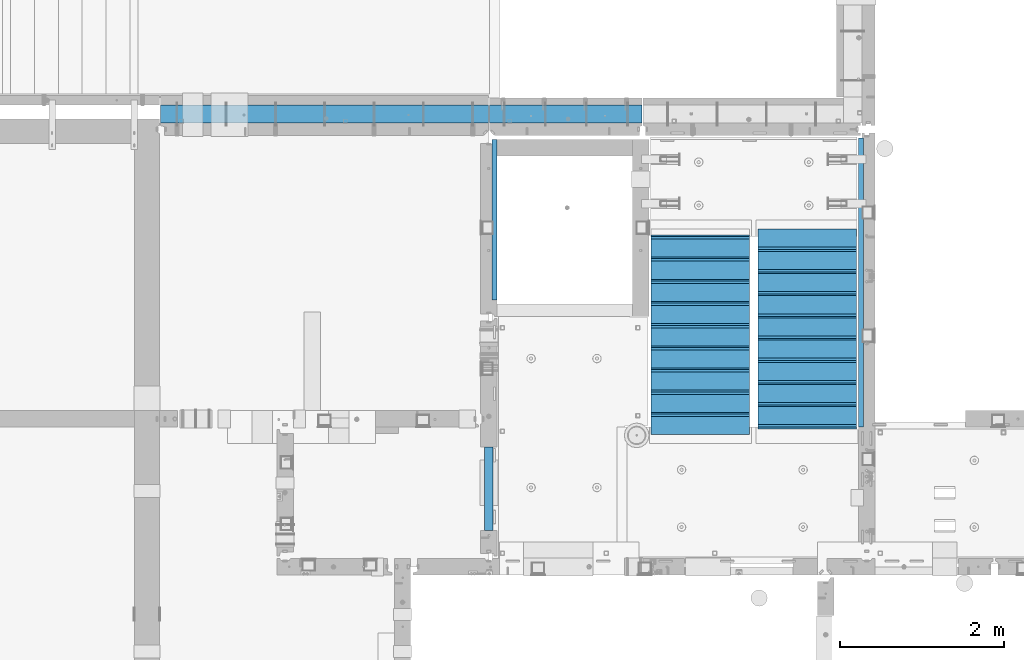
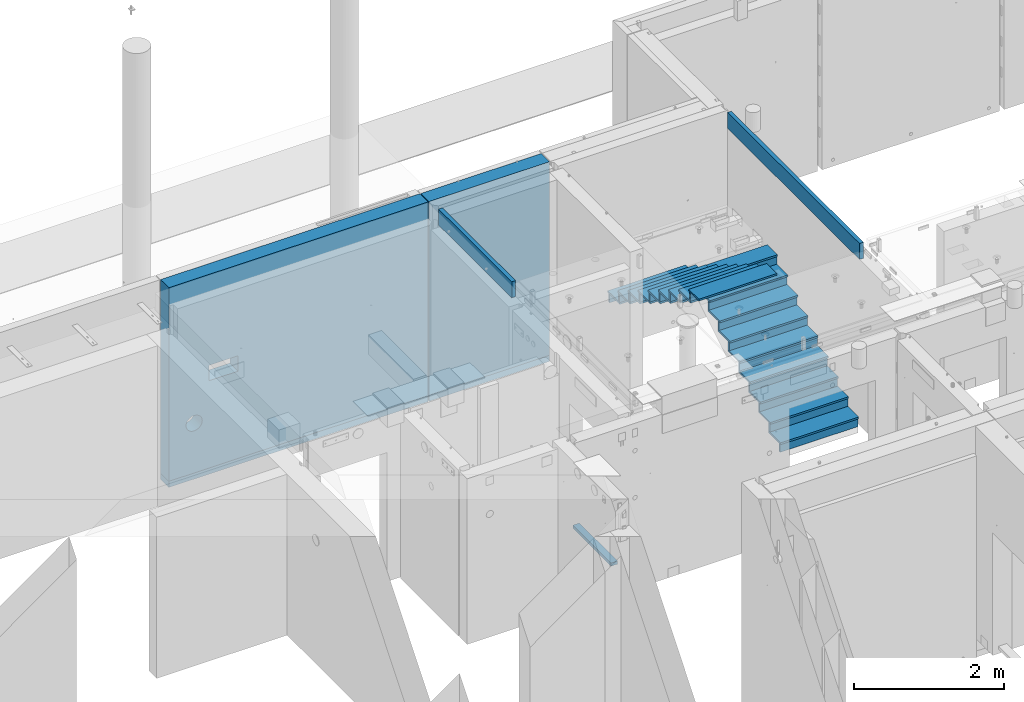
# One storey, part 81 of 264: 43 beams, 9 elements without a shape of their own.
"""IFC2X3 building model written with IfcOpenShell, lengths in millimetres."""

from ifc_helpers import new_model, si_unit, frame, origin_with_axes, place, context, subcontext, project, spatial, faceted_brep, material, type_object, element, aggregate, save


model = new_model("IFC2X3")

# Units and contexts
model_context = context("Model", 3, precision=1e-05, world=origin_with_axes())
body_context = subcontext(model_context, "Body", "Model", "MODEL_VIEW")
ifc_project = project(units=[si_unit("LENGTHUNIT", "METRE", prefix="MILLI"), si_unit("AREAUNIT", "SQUARE_METRE"), si_unit("VOLUMEUNIT", "CUBIC_METRE"), si_unit("MASSUNIT", "GRAM", prefix="KILO"), si_unit("TIMEUNIT", "SECOND"), si_unit("PLANEANGLEUNIT", "RADIAN"), si_unit("SOLIDANGLEUNIT", "STERADIAN"), si_unit("THERMODYNAMICTEMPERATUREUNIT", "DEGREE_CELSIUS"), si_unit("LUMINOUSINTENSITYUNIT", "LUMEN")], contexts=[model_context])

# Site, building, storey
site_placement = place(None, origin_with_axes())
site = spatial("IfcSite", under=ifc_project, at=site_placement, CompositionType="ELEMENT")
building_placement = place(site_placement, origin_with_axes())
building = spatial("IfcBuilding", under=site, at=building_placement, CompositionType="ELEMENT")
storey_placement = place(building_placement, origin_with_axes())
storey = spatial("IfcBuildingStorey", under=building, at=storey_placement, Name="K", CompositionType="ELEMENT", Elevation=0.0)

# Assembly, beam
assembly_1_placement = place(storey_placement, origin_with_axes())
assembly_1 = element("IfcElementAssembly", 1, at=assembly_1_placement, inside=storey, AssemblyPlace="NOTDEFINED", PredefinedType="REINFORCEMENT_UNIT")
ifc_material_1 = material(Name="CONCRETE/C25/30")
beam_type_1 = type_object("IfcBeamType", Name="260X60", PredefinedType="NOTDEFINED")
beam_1_placement = place(assembly_1_placement, frame((17779.9999105288, 18424.9992663657, 81600.0), z_axis=(0.0, 0.0, 1.0), x_axis=(0.0, 1.0, 0.0)))
beam_1 = element("IfcBeam", 2, at=beam_1_placement, type_object=beam_type_1, material=ifc_material_1, ObjectType="260X60", context=body_context, shape_type="Brep", body=[
    faceted_brep([(0.0, 30.0, -130.0), (0.0, 30.0, 130.0), (1954.9989445891, 30.0, 130.0), (1954.9989445891, 30.0, -130.0), (0.0, -30.0, 130.0), (1954.9989445891, -30.0, 130.0), (0.0, -30.0, -130.0), (1954.9989445891, -30.0, -130.0)], [[[0, 1, 2, 3]], [[1, 4, 5, 2]], [[4, 6, 7, 5]], [[6, 0, 3, 7]], [[5, 7, 3, 2]], [[6, 4, 1, 0]]]),
])
aggregate(assembly_1, [beam_1])

assembly_2_placement = place(storey_placement, origin_with_axes())
assembly_2 = element("IfcElementAssembly", 3, at=assembly_2_placement, inside=storey, AssemblyPlace="NOTDEFINED", PredefinedType="REINFORCEMENT_UNIT")
beam_2_placement = place(assembly_2_placement, frame((22240.0000000001, 20400.0, 81600.0), z_axis=(0.0, 0.0, 1.0), x_axis=(0.0, -1.0, 0.0)))
beam_2 = element("IfcBeam", 4, at=beam_2_placement, type_object=beam_type_1, material=ifc_material_1, ObjectType="260X60", context=body_context, shape_type="Brep", body=[
    faceted_brep([(0.0, 30.0, -130.0), (0.0, 30.0, 130.0), (3520.0, 30.0, 130.0), (3520.0, 30.0, -130.0), (0.0, -30.0, 130.0), (3520.0, -30.0, 130.0), (0.0, -30.0, -130.0), (3520.0, -30.0, -130.0)], [[[0, 1, 2, 3]], [[1, 4, 5, 2]], [[4, 6, 7, 5]], [[6, 0, 3, 7]], [[5, 7, 3, 2]], [[6, 4, 1, 0]]]),
])
aggregate(assembly_2, [beam_2])

assembly_3_placement = place(storey_placement, origin_with_axes())
assembly_3 = element("IfcElementAssembly", 5, at=assembly_3_placement, inside=storey, AssemblyPlace="NOTDEFINED", PredefinedType="REINFORCEMENT_UNIT")
ifc_material_2 = material(Name="TIMBER/T24")
beam_type_2 = type_object("IfcBeamType", PredefinedType="NOTDEFINED")
beam_3_placement = place(assembly_3_placement, frame((17710.0, 15620.0003036857, 78860.0), z_axis=(0.0, 0.0, 1.0), x_axis=(0.0, 1.0, 0.0)))
beam_3 = element("IfcBeam", 6, at=beam_3_placement, type_object=beam_type_2, material=ifc_material_2, context=body_context, shape_type="Brep", body=[
    faceted_brep([(0.0, 50.0, -25.0), (0.0, 50.0, 25.0), (1020.0, 50.0, 25.0), (1020.0, 50.0, -25.0), (0.0, -50.0, 25.0), (1020.0, -50.0, 25.0), (0.0, -50.0, -25.0), (1020.0, -50.0, -25.0)], [[[0, 1, 2, 3]], [[1, 4, 5, 2]], [[4, 6, 7, 5]], [[6, 0, 3, 7]], [[5, 7, 3, 2]], [[6, 4, 1, 0]]]),
])
aggregate(assembly_3, [beam_3])

assembly_4_placement = place(storey_placement, origin_with_axes())
assembly_4 = element("IfcElementAssembly", 7, at=assembly_4_placement, inside=storey, AssemblyPlace="NOTDEFINED", PredefinedType="REINFORCEMENT_UNIT")
beam_type_3 = type_object("IfcBeamType", PredefinedType="NOTDEFINED")
beam_4_placement = place(assembly_4_placement, frame((19575.0014026565, 20689.9988548915, 78540.0), z_axis=(0.0, 0.0, 1.0), x_axis=(-1.0, 3.00000001838171e-08, 0.0)))
beam_4 = element("IfcBeam", 8, at=beam_4_placement, type_object=beam_type_3, material=ifc_material_1, context=body_context, shape_type="Brep", body=[
    faceted_brep([(-3.63797880709171e-12, 109.999999999996, -50.0), (-3.63797880709171e-12, 109.999999999996, 50.0), (1855.00147016809, 109.999999999996, 50.0), (1855.00147016809, 109.999999999996, -50.0), (-3.63797880709171e-12, -110.0, 50.0), (1855.00147016809, -110.0, 50.0), (-3.63797880709171e-12, -110.0, -50.0), (1855.00147016809, -110.0, -50.0)], [[[0, 1, 2, 3]], [[1, 4, 5, 2]], [[4, 6, 7, 5]], [[6, 0, 3, 7]], [[5, 7, 3, 2]], [[6, 4, 1, 0]]]),
])

assembly_5_placement = place(storey_placement, origin_with_axes())
assembly_5 = element("IfcElementAssembly", 9, at=assembly_5_placement, inside=storey, AssemblyPlace="NOTDEFINED", PredefinedType="REINFORCEMENT_UNIT")
beam_5_placement = place(assembly_5_placement, frame((13715.0034045212, 20689.9999956824, 78540.0), z_axis=(0.0, 0.0, 1.0), x_axis=(1.0, 0.0, 0.0)))
beam_5 = element("IfcBeam", 10, at=beam_5_placement, type_object=beam_type_3, material=ifc_material_1, context=body_context, shape_type="Brep", body=[
    faceted_brep([(-3.63797880709171e-12, 109.999999999996, -50.0), (-3.63797880709171e-12, 109.999999999996, 50.0), (3989.996563799, 110.000000000004, 50.0), (3989.996563799, 110.000000000004, -50.0), (-3.63797880709171e-12, -110.0, 50.0), (3989.996627159, -109.999999999996, 50.0), (-3.63797880709171e-12, -110.0, -50.0), (3989.996627159, -109.999999999996, -50.0)], [[[0, 1, 2, 3]], [[1, 4, 5, 2]], [[4, 6, 7, 5]], [[6, 0, 3, 7]], [[5, 7, 3, 2]], [[6, 4, 1, 0]]]),
])

# Assembly, beams
assembly_6_placement = place(storey_placement, origin_with_axes())
assembly_6 = element("IfcElementAssembly", 11, at=assembly_6_placement, inside=storey, Name="E9", AssemblyPlace="NOTDEFINED", PredefinedType="NOTDEFINED")
ifc_material_3 = material(Name="Undefined/C32/40")
beam_type_4 = type_object("IfcBeamType", PredefinedType="NOTDEFINED")
beam_6_placement = place(assembly_6_placement, frame((20885.0002457424, 17024.9998138874, 81662.1), z_axis=(0.0, 1.0, 0.0), x_axis=(-1.0, 3.00000001838171e-08, 0.0)))
beam_6 = element("IfcBeam", 12, at=beam_6_placement, type_object=beam_type_4, material=ifc_material_3, Name="E9", context=body_context, shape_type="Brep", body=[
    faceted_brep([(0.0, 68.5, -15.0), (0.0, 68.5, 15.0), (1200.0, 68.5, 15.0), (1200.0, 68.5, -15.0), (0.0, -68.5, 15.0), (1200.0, -68.5, 15.0), (0.0, -68.5, -15.0), (1200.0, -68.5, -15.0)], [[[0, 1, 2, 3]], [[1, 4, 5, 2]], [[4, 6, 7, 5]], [[6, 0, 3, 7]], [[5, 7, 3, 2]], [[6, 4, 1, 0]]]),
])
beam_7_placement = place(assembly_6_placement, frame((20885.0002457424, 17294.9998138874, 81495.4), z_axis=(0.0, 1.0, 0.0), x_axis=(-1.0, 3.00000001838171e-08, 0.0)))
beam_7 = element("IfcBeam", 13, at=beam_7_placement, type_object=beam_type_4, material=ifc_material_3, Name="E9", context=body_context, shape_type="Brep", body=[
    faceted_brep([(0.0, 68.5, -15.0), (0.0, 68.5, 15.0), (1200.0, 68.5, 15.0), (1200.0, 68.5, -15.0), (0.0, -68.5, 15.0), (1200.0, -68.5, 15.0), (0.0, -68.5, -15.0), (1200.0, -68.5, -15.0)], [[[0, 1, 2, 3]], [[1, 4, 5, 2]], [[4, 6, 7, 5]], [[6, 0, 3, 7]], [[5, 7, 3, 2]], [[6, 4, 1, 0]]]),
])
beam_8_placement = place(assembly_6_placement, frame((20885.0002457424, 17564.9998138874, 81328.7), z_axis=(0.0, 1.0, 0.0), x_axis=(-1.0, 3.00000001838171e-08, 0.0)))
beam_8 = element("IfcBeam", 14, at=beam_8_placement, type_object=beam_type_4, material=ifc_material_3, Name="E9", context=body_context, shape_type="Brep", body=[
    faceted_brep([(0.0, 68.5, -15.0), (0.0, 68.5, 15.0), (1200.0, 68.5, 15.0), (1200.0, 68.5, -15.0), (0.0, -68.5, 15.0), (1200.0, -68.5, 15.0), (0.0, -68.5, -15.0), (1200.0, -68.5, -15.0)], [[[0, 1, 2, 3]], [[1, 4, 5, 2]], [[4, 6, 7, 5]], [[6, 0, 3, 7]], [[5, 7, 3, 2]], [[6, 4, 1, 0]]]),
])
beam_9_placement = place(assembly_6_placement, frame((20885.0002457424, 17834.9998138874, 81162.0), z_axis=(0.0, 1.0, 0.0), x_axis=(-1.0, 3.00000001838171e-08, 0.0)))
beam_9 = element("IfcBeam", 15, at=beam_9_placement, type_object=beam_type_4, material=ifc_material_3, Name="E9", context=body_context, shape_type="Brep", body=[
    faceted_brep([(0.0, 68.5, -15.0), (0.0, 68.5, 15.0), (1200.0, 68.5, 15.0), (1200.0, 68.5, -15.0), (0.0, -68.5, 15.0), (1200.0, -68.5, 15.0), (0.0, -68.5, -15.0), (1200.0, -68.5, -15.0)], [[[0, 1, 2, 3]], [[1, 4, 5, 2]], [[4, 6, 7, 5]], [[6, 0, 3, 7]], [[5, 7, 3, 2]], [[6, 4, 1, 0]]]),
])
beam_10_placement = place(assembly_6_placement, frame((20885.0002457424, 18104.9998138874, 80995.3), z_axis=(0.0, 1.0, 0.0), x_axis=(-1.0, 3.00000001838171e-08, 0.0)))
beam_10 = element("IfcBeam", 16, at=beam_10_placement, type_object=beam_type_4, material=ifc_material_3, Name="E9", context=body_context, shape_type="Brep", body=[
    faceted_brep([(0.0, 68.5, -15.0), (0.0, 68.5, 15.0), (1200.0, 68.5, 15.0), (1200.0, 68.5, -15.0), (0.0, -68.5, 15.0), (1200.0, -68.5, 15.0), (0.0, -68.5, -15.0), (1200.0, -68.5, -15.0)], [[[0, 1, 2, 3]], [[1, 4, 5, 2]], [[4, 6, 7, 5]], [[6, 0, 3, 7]], [[5, 7, 3, 2]], [[6, 4, 1, 0]]]),
])
beam_11_placement = place(assembly_6_placement, frame((20885.0002457424, 18374.9998138874, 80828.6), z_axis=(0.0, 1.0, 0.0), x_axis=(-1.0, 3.00000001838171e-08, 0.0)))
beam_11 = element("IfcBeam", 17, at=beam_11_placement, type_object=beam_type_4, material=ifc_material_3, Name="E9", context=body_context, shape_type="Brep", body=[
    faceted_brep([(0.0, 68.5, -15.0), (0.0, 68.5, 15.0), (1200.0, 68.5, 15.0), (1200.0, 68.5, -15.0), (0.0, -68.5, 15.0), (1200.0, -68.5, 15.0), (0.0, -68.5, -15.0), (1200.0, -68.5, -15.0)], [[[0, 1, 2, 3]], [[1, 4, 5, 2]], [[4, 6, 7, 5]], [[6, 0, 3, 7]], [[5, 7, 3, 2]], [[6, 4, 1, 0]]]),
])
beam_12_placement = place(assembly_6_placement, frame((20885.0002457424, 18644.9998138874, 80661.9), z_axis=(0.0, 1.0, 0.0), x_axis=(-1.0, 3.00000001838171e-08, 0.0)))
beam_12 = element("IfcBeam", 18, at=beam_12_placement, type_object=beam_type_4, material=ifc_material_3, Name="E9", context=body_context, shape_type="Brep", body=[
    faceted_brep([(0.0, 68.5, -15.0), (0.0, 68.5, 15.0), (1200.0, 68.5, 15.0), (1200.0, 68.5, -15.0), (0.0, -68.5, 15.0), (1200.0, -68.5, 15.0), (0.0, -68.5, -15.0), (1200.0, -68.5, -15.0)], [[[0, 1, 2, 3]], [[1, 4, 5, 2]], [[4, 6, 7, 5]], [[6, 0, 3, 7]], [[5, 7, 3, 2]], [[6, 4, 1, 0]]]),
])
beam_13_placement = place(assembly_6_placement, frame((20885.0002457424, 18914.9998138874, 80495.2), z_axis=(0.0, 1.0, 0.0), x_axis=(-1.0, 3.00000001838171e-08, 0.0)))
beam_13 = element("IfcBeam", 19, at=beam_13_placement, type_object=beam_type_4, material=ifc_material_3, Name="E9", context=body_context, shape_type="Brep", body=[
    faceted_brep([(0.0, 68.5, -15.0), (0.0, 68.5, 15.0), (1200.0, 68.5, 15.0), (1200.0, 68.5, -15.0), (0.0, -68.5, 15.0), (1200.0, -68.5, 15.0), (0.0, -68.5, -15.0), (1200.0, -68.5, -15.0)], [[[0, 1, 2, 3]], [[1, 4, 5, 2]], [[4, 6, 7, 5]], [[6, 0, 3, 7]], [[5, 7, 3, 2]], [[6, 4, 1, 0]]]),
])
beam_14_placement = place(assembly_6_placement, frame((20885.0002457424, 19184.9998138874, 80328.5), z_axis=(0.0, 1.0, 0.0), x_axis=(-1.0, 3.00000001838171e-08, 0.0)))
beam_14 = element("IfcBeam", 20, at=beam_14_placement, type_object=beam_type_4, material=ifc_material_3, Name="E9", context=body_context, shape_type="Brep", body=[
    faceted_brep([(0.0, 68.5, -15.0), (0.0, 68.5, 15.0), (1200.0, 68.5, 15.0), (1200.0, 68.5, -15.0), (0.0, -68.5, 15.0), (1200.0, -68.5, 15.0), (0.0, -68.5, -15.0), (1200.0, -68.5, -15.0)], [[[0, 1, 2, 3]], [[1, 4, 5, 2]], [[4, 6, 7, 5]], [[6, 0, 3, 7]], [[5, 7, 3, 2]], [[6, 4, 1, 0]]]),
])

assembly_7_placement = place(storey_placement, origin_with_axes())
assembly_7 = element("IfcElementAssembly", 21, at=assembly_7_placement, inside=storey, Name="E9", AssemblyPlace="NOTDEFINED", PredefinedType="NOTDEFINED")
beam_15_placement = place(assembly_7_placement, frame((20985.002175553, 18785.0053086308, 79995.098366371), z_axis=(0.0, -1.0, 0.0), x_axis=(1.0, 0.0, 0.0)))
beam_15 = element("IfcBeam", 22, at=beam_15_placement, type_object=beam_type_4, material=ifc_material_3, Name="E9", context=body_context, shape_type="Brep", body=[
    faceted_brep([(0.0, 68.5, -15.0), (0.0, 68.5, 15.0), (1200.0, 68.5, 15.0), (1200.0, 68.5, -15.0), (0.0, -68.5, 15.0), (1200.0, -68.5, 15.0), (0.0, -68.5, -15.0), (1200.0, -68.5, -15.0)], [[[0, 1, 2, 3]], [[1, 4, 5, 2]], [[4, 6, 7, 5]], [[6, 0, 3, 7]], [[5, 7, 3, 2]], [[6, 4, 1, 0]]]),
])
beam_16_placement = place(assembly_7_placement, frame((20985.002175553, 18515.0053086308, 79828.398366371), z_axis=(0.0, -1.0, 0.0), x_axis=(1.0, 0.0, 0.0)))
beam_16 = element("IfcBeam", 23, at=beam_16_placement, type_object=beam_type_4, material=ifc_material_3, Name="E9", context=body_context, shape_type="Brep", body=[
    faceted_brep([(0.0, 68.5, -15.0), (0.0, 68.5, 15.0), (1200.0, 68.5, 15.0), (1200.0, 68.5, -15.0), (0.0, -68.5, 15.0), (1200.0, -68.5, 15.0), (0.0, -68.5, -15.0), (1200.0, -68.5, -15.0)], [[[0, 1, 2, 3]], [[1, 4, 5, 2]], [[4, 6, 7, 5]], [[6, 0, 3, 7]], [[5, 7, 3, 2]], [[6, 4, 1, 0]]]),
])
beam_17_placement = place(assembly_7_placement, frame((20985.002175553, 18245.0053086308, 79661.698366371), z_axis=(0.0, -1.0, 0.0), x_axis=(1.0, 0.0, 0.0)))
beam_17 = element("IfcBeam", 24, at=beam_17_placement, type_object=beam_type_4, material=ifc_material_3, Name="E9", context=body_context, shape_type="Brep", body=[
    faceted_brep([(0.0, 68.5, -15.0), (0.0, 68.5, 15.0), (1200.0, 68.5, 15.0), (1200.0, 68.5, -15.0), (0.0, -68.5, 15.0), (1200.0, -68.5, 15.0), (0.0, -68.5, -15.0), (1200.0, -68.5, -15.0)], [[[0, 1, 2, 3]], [[1, 4, 5, 2]], [[4, 6, 7, 5]], [[6, 0, 3, 7]], [[5, 7, 3, 2]], [[6, 4, 1, 0]]]),
])
beam_18_placement = place(assembly_7_placement, frame((20985.002175553, 17975.0053086308, 79494.998366371), z_axis=(0.0, -1.0, 0.0), x_axis=(1.0, 0.0, 0.0)))
beam_18 = element("IfcBeam", 25, at=beam_18_placement, type_object=beam_type_4, material=ifc_material_3, Name="E9", context=body_context, shape_type="Brep", body=[
    faceted_brep([(0.0, 68.5, -15.0), (0.0, 68.5, 15.0), (1200.0, 68.5, 15.0), (1200.0, 68.5, -15.0), (0.0, -68.5, 15.0), (1200.0, -68.5, 15.0), (0.0, -68.5, -15.0), (1200.0, -68.5, -15.0)], [[[0, 1, 2, 3]], [[1, 4, 5, 2]], [[4, 6, 7, 5]], [[6, 0, 3, 7]], [[5, 7, 3, 2]], [[6, 4, 1, 0]]]),
])
beam_19_placement = place(assembly_7_placement, frame((20985.002175553, 17705.0053086308, 79328.298366371), z_axis=(0.0, -1.0, 0.0), x_axis=(1.0, 0.0, 0.0)))
beam_19 = element("IfcBeam", 26, at=beam_19_placement, type_object=beam_type_4, material=ifc_material_3, Name="E9", context=body_context, shape_type="Brep", body=[
    faceted_brep([(0.0, 68.5, -15.0), (0.0, 68.5, 15.0), (1200.0, 68.5, 15.0), (1200.0, 68.5, -15.0), (0.0, -68.5, 15.0), (1200.0, -68.5, 15.0), (0.0, -68.5, -15.0), (1200.0, -68.5, -15.0)], [[[0, 1, 2, 3]], [[1, 4, 5, 2]], [[4, 6, 7, 5]], [[6, 0, 3, 7]], [[5, 7, 3, 2]], [[6, 4, 1, 0]]]),
])
beam_20_placement = place(assembly_7_placement, frame((20985.002175553, 17435.0053086308, 79161.598366371), z_axis=(0.0, -1.0, 0.0), x_axis=(1.0, 0.0, 0.0)))
beam_20 = element("IfcBeam", 27, at=beam_20_placement, type_object=beam_type_4, material=ifc_material_3, Name="E9", context=body_context, shape_type="Brep", body=[
    faceted_brep([(0.0, 68.5, -15.0), (0.0, 68.5, 15.0), (1200.0, 68.5, 15.0), (1200.0, 68.5, -15.0), (0.0, -68.5, 15.0), (1200.0, -68.5, 15.0), (0.0, -68.5, -15.0), (1200.0, -68.5, -15.0)], [[[0, 1, 2, 3]], [[1, 4, 5, 2]], [[4, 6, 7, 5]], [[6, 0, 3, 7]], [[5, 7, 3, 2]], [[6, 4, 1, 0]]]),
])
beam_21_placement = place(assembly_7_placement, frame((20985.002175553, 17165.0053086308, 78994.898366371), z_axis=(0.0, -1.0, 0.0), x_axis=(1.0, 0.0, 0.0)))
beam_21 = element("IfcBeam", 28, at=beam_21_placement, type_object=beam_type_4, material=ifc_material_3, Name="E9", context=body_context, shape_type="Brep", body=[
    faceted_brep([(0.0, 68.5, -15.0), (0.0, 68.5, 15.0), (1200.0, 68.5, 15.0), (1200.0, 68.5, -15.0), (0.0, -68.5, 15.0), (1200.0, -68.5, 15.0), (0.0, -68.5, -15.0), (1200.0, -68.5, -15.0)], [[[0, 1, 2, 3]], [[1, 4, 5, 2]], [[4, 6, 7, 5]], [[6, 0, 3, 7]], [[5, 7, 3, 2]], [[6, 4, 1, 0]]]),
])
beam_22_placement = place(assembly_7_placement, frame((20985.002175553, 19055.0053086308, 80161.798366371), z_axis=(0.0, -1.0, 0.0), x_axis=(1.0, 0.0, 0.0)))
beam_22 = element("IfcBeam", 29, at=beam_22_placement, type_object=beam_type_4, material=ifc_material_3, Name="E9", context=body_context, shape_type="Brep", body=[
    faceted_brep([(0.0, 68.5, -15.0), (0.0, 68.5, 15.0), (1200.0, 68.5, 15.0), (1200.0, 68.5, -15.0), (0.0, -68.5, 15.0), (1200.0, -68.5, 15.0), (0.0, -68.5, -15.0), (1200.0, -68.5, -15.0)], [[[0, 1, 2, 3]], [[1, 4, 5, 2]], [[4, 6, 7, 5]], [[6, 0, 3, 7]], [[5, 7, 3, 2]], [[6, 4, 1, 0]]]),
])
beam_23_placement = place(assembly_7_placement, frame((20985.002175553, 16895.0053086308, 78828.198366371), z_axis=(0.0, -1.0, 0.0), x_axis=(1.0, 0.0, 0.0)))
beam_23 = element("IfcBeam", 30, at=beam_23_placement, type_object=beam_type_4, material=ifc_material_3, Name="E9", context=body_context, shape_type="Brep", body=[
    faceted_brep([(0.0, 68.5, -15.0), (0.0, 68.5, 15.0), (1200.0, 68.5, 15.0), (1200.0, 68.5, -15.0), (0.0, -68.5, 15.0), (1200.0, -68.5, 15.0), (0.0, -68.5, -15.0), (1200.0, -68.5, -15.0)], [[[0, 1, 2, 3]], [[1, 4, 5, 2]], [[4, 6, 7, 5]], [[6, 0, 3, 7]], [[5, 7, 3, 2]], [[6, 4, 1, 0]]]),
])

# Beam
beam_type_5 = type_object("IfcBeamType", PredefinedType="NOTDEFINED")
beam_24_placement = place(assembly_6_placement, frame((20885.0002457424, 17169.9998138874, 81578.6), z_axis=(0.0, 1.0, 0.0), x_axis=(-1.0, 3.00000001838171e-08, 0.0)))
beam_24 = element("IfcBeam", 31, at=beam_24_placement, type_object=beam_type_5, material=ifc_material_3, Name="E9", context=body_context, shape_type="Brep", body=[
    faceted_brep([(0.0, 15.0, -160.0), (0.0, 15.0, 160.0), (1200.0, 15.0, 160.0), (1200.0, 15.0, -160.0), (0.0, -15.0, 160.0), (1200.0, -15.0, 160.0), (0.0, -15.0, -160.0), (1200.0, -15.0, -160.0)], [[[0, 1, 2, 3]], [[1, 4, 5, 2]], [[4, 6, 7, 5]], [[6, 0, 3, 7]], [[5, 7, 3, 2]], [[6, 4, 1, 0]]]),
])

beam_25_placement = place(assembly_6_placement, frame((20885.0002457424, 17439.9998138874, 81411.9), z_axis=(0.0, 1.0, 0.0), x_axis=(-1.0, 3.00000001838171e-08, 0.0)))
beam_25 = element("IfcBeam", 32, at=beam_25_placement, type_object=beam_type_5, material=ifc_material_3, Name="E9", context=body_context, shape_type="Brep", body=[
    faceted_brep([(0.0, 15.0, -160.0), (0.0, 15.0, 160.0), (1200.0, 15.0, 160.0), (1200.0, 15.0, -160.0), (0.0, -15.0, 160.0), (1200.0, -15.0, 160.0), (0.0, -15.0, -160.0), (1200.0, -15.0, -160.0)], [[[0, 1, 2, 3]], [[1, 4, 5, 2]], [[4, 6, 7, 5]], [[6, 0, 3, 7]], [[5, 7, 3, 2]], [[6, 4, 1, 0]]]),
])

beam_26_placement = place(assembly_6_placement, frame((20885.0002457424, 17709.9998138874, 81245.2), z_axis=(0.0, 1.0, 0.0), x_axis=(-1.0, 3.00000001838171e-08, 0.0)))
beam_26 = element("IfcBeam", 33, at=beam_26_placement, type_object=beam_type_5, material=ifc_material_3, Name="E9", context=body_context, shape_type="Brep", body=[
    faceted_brep([(0.0, 15.0, -160.0), (0.0, 15.0, 160.0), (1200.0, 15.0, 160.0), (1200.0, 15.0, -160.0), (0.0, -15.0, 160.0), (1200.0, -15.0, 160.0), (0.0, -15.0, -160.0), (1200.0, -15.0, -160.0)], [[[0, 1, 2, 3]], [[1, 4, 5, 2]], [[4, 6, 7, 5]], [[6, 0, 3, 7]], [[5, 7, 3, 2]], [[6, 4, 1, 0]]]),
])

beam_27_placement = place(assembly_6_placement, frame((20885.0002457424, 17979.9998138874, 81078.5), z_axis=(0.0, 1.0, 0.0), x_axis=(-1.0, 3.00000001838171e-08, 0.0)))
beam_27 = element("IfcBeam", 34, at=beam_27_placement, type_object=beam_type_5, material=ifc_material_3, Name="E9", context=body_context, shape_type="Brep", body=[
    faceted_brep([(0.0, 15.0, -160.0), (0.0, 15.0, 160.0), (1200.0, 15.0, 160.0), (1200.0, 15.0, -160.0), (0.0, -15.0, 160.0), (1200.0, -15.0, 160.0), (0.0, -15.0, -160.0), (1200.0, -15.0, -160.0)], [[[0, 1, 2, 3]], [[1, 4, 5, 2]], [[4, 6, 7, 5]], [[6, 0, 3, 7]], [[5, 7, 3, 2]], [[6, 4, 1, 0]]]),
])

beam_28_placement = place(assembly_6_placement, frame((20885.0002457424, 18249.9998138874, 80911.8), z_axis=(0.0, 1.0, 0.0), x_axis=(-1.0, 3.00000001838171e-08, 0.0)))
beam_28 = element("IfcBeam", 35, at=beam_28_placement, type_object=beam_type_5, material=ifc_material_3, Name="E9", context=body_context, shape_type="Brep", body=[
    faceted_brep([(0.0, 15.0, -160.0), (0.0, 15.0, 160.0), (1200.0, 15.0, 160.0), (1200.0, 15.0, -160.0), (0.0, -15.0, 160.0), (1200.0, -15.0, 160.0), (0.0, -15.0, -160.0), (1200.0, -15.0, -160.0)], [[[0, 1, 2, 3]], [[1, 4, 5, 2]], [[4, 6, 7, 5]], [[6, 0, 3, 7]], [[5, 7, 3, 2]], [[6, 4, 1, 0]]]),
])

beam_29_placement = place(assembly_6_placement, frame((20885.0002457424, 18519.9998138874, 80745.1), z_axis=(0.0, 1.0, 0.0), x_axis=(-1.0, 3.00000001838171e-08, 0.0)))
beam_29 = element("IfcBeam", 36, at=beam_29_placement, type_object=beam_type_5, material=ifc_material_3, Name="E9", context=body_context, shape_type="Brep", body=[
    faceted_brep([(0.0, 15.0, -160.0), (0.0, 15.0, 160.0), (1200.0, 15.0, 160.0), (1200.0, 15.0, -160.0), (0.0, -15.0, 160.0), (1200.0, -15.0, 160.0), (0.0, -15.0, -160.0), (1200.0, -15.0, -160.0)], [[[0, 1, 2, 3]], [[1, 4, 5, 2]], [[4, 6, 7, 5]], [[6, 0, 3, 7]], [[5, 7, 3, 2]], [[6, 4, 1, 0]]]),
])

beam_30_placement = place(assembly_6_placement, frame((20885.0002457424, 18789.9998138874, 80578.4), z_axis=(0.0, 1.0, 0.0), x_axis=(-1.0, 3.00000001838171e-08, 0.0)))
beam_30 = element("IfcBeam", 37, at=beam_30_placement, type_object=beam_type_5, material=ifc_material_3, Name="E9", context=body_context, shape_type="Brep", body=[
    faceted_brep([(0.0, 15.0, -160.0), (0.0, 15.0, 160.0), (1200.0, 15.0, 160.0), (1200.0, 15.0, -160.0), (0.0, -15.0, 160.0), (1200.0, -15.0, 160.0), (0.0, -15.0, -160.0), (1200.0, -15.0, -160.0)], [[[0, 1, 2, 3]], [[1, 4, 5, 2]], [[4, 6, 7, 5]], [[6, 0, 3, 7]], [[5, 7, 3, 2]], [[6, 4, 1, 0]]]),
])

beam_31_placement = place(assembly_6_placement, frame((20885.0002457424, 19059.9998138874, 80411.7), z_axis=(0.0, 1.0, 0.0), x_axis=(-1.0, 3.00000001838171e-08, 0.0)))
beam_31 = element("IfcBeam", 38, at=beam_31_placement, type_object=beam_type_5, material=ifc_material_3, Name="E9", context=body_context, shape_type="Brep", body=[
    faceted_brep([(0.0, 15.0, -160.0), (0.0, 15.0, 160.0), (1200.0, 15.0, 160.0), (1200.0, 15.0, -160.0), (0.0, -15.0, 160.0), (1200.0, -15.0, 160.0), (0.0, -15.0, -160.0), (1200.0, -15.0, -160.0)], [[[0, 1, 2, 3]], [[1, 4, 5, 2]], [[4, 6, 7, 5]], [[6, 0, 3, 7]], [[5, 7, 3, 2]], [[6, 4, 1, 0]]]),
])

beam_32_placement = place(assembly_7_placement, frame((20985.002175553, 18910.0053086308, 80078.298366371), z_axis=(0.0, -1.0, 0.0), x_axis=(1.0, 0.0, 0.0)))
beam_32 = element("IfcBeam", 39, at=beam_32_placement, type_object=beam_type_5, material=ifc_material_3, Name="E9", context=body_context, shape_type="Brep", body=[
    faceted_brep([(0.0, 15.0, -160.0), (0.0, 15.0, 160.0), (1200.0, 15.0, 160.0), (1200.0, 15.0, -160.0), (0.0, -15.0, 160.0), (1200.0, -15.0, 160.0), (0.0, -15.0, -160.0), (1200.0, -15.0, -160.0)], [[[0, 1, 2, 3]], [[1, 4, 5, 2]], [[4, 6, 7, 5]], [[6, 0, 3, 7]], [[5, 7, 3, 2]], [[6, 4, 1, 0]]]),
])

beam_33_placement = place(assembly_7_placement, frame((20985.002175553, 18640.0053086308, 79911.598366371), z_axis=(0.0, -1.0, 0.0), x_axis=(1.0, 0.0, 0.0)))
beam_33 = element("IfcBeam", 40, at=beam_33_placement, type_object=beam_type_5, material=ifc_material_3, Name="E9", context=body_context, shape_type="Brep", body=[
    faceted_brep([(0.0, 15.0, -160.0), (0.0, 15.0, 160.0), (1200.0, 15.0, 160.0), (1200.0, 15.0, -160.0), (0.0, -15.0, 160.0), (1200.0, -15.0, 160.0), (0.0, -15.0, -160.0), (1200.0, -15.0, -160.0)], [[[0, 1, 2, 3]], [[1, 4, 5, 2]], [[4, 6, 7, 5]], [[6, 0, 3, 7]], [[5, 7, 3, 2]], [[6, 4, 1, 0]]]),
])

beam_34_placement = place(assembly_7_placement, frame((20985.002175553, 18100.0053086308, 79578.198366371), z_axis=(0.0, -1.0, 0.0), x_axis=(1.0, 0.0, 0.0)))
beam_34 = element("IfcBeam", 41, at=beam_34_placement, type_object=beam_type_5, material=ifc_material_3, Name="E9", context=body_context, shape_type="Brep", body=[
    faceted_brep([(0.0, 15.0, -160.0), (0.0, 15.0, 160.0), (1200.0, 15.0, 160.0), (1200.0, 15.0, -160.0), (0.0, -15.0, 160.0), (1200.0, -15.0, 160.0), (0.0, -15.0, -160.0), (1200.0, -15.0, -160.0)], [[[0, 1, 2, 3]], [[1, 4, 5, 2]], [[4, 6, 7, 5]], [[6, 0, 3, 7]], [[5, 7, 3, 2]], [[6, 4, 1, 0]]]),
])

beam_35_placement = place(assembly_7_placement, frame((20985.002175553, 17830.0053086308, 79411.498366371), z_axis=(0.0, -1.0, 0.0), x_axis=(1.0, 0.0, 0.0)))
beam_35 = element("IfcBeam", 42, at=beam_35_placement, type_object=beam_type_5, material=ifc_material_3, Name="E9", context=body_context, shape_type="Brep", body=[
    faceted_brep([(0.0, 15.0, -160.0), (0.0, 15.0, 160.0), (1200.0, 15.0, 160.0), (1200.0, 15.0, -160.0), (0.0, -15.0, 160.0), (1200.0, -15.0, 160.0), (0.0, -15.0, -160.0), (1200.0, -15.0, -160.0)], [[[0, 1, 2, 3]], [[1, 4, 5, 2]], [[4, 6, 7, 5]], [[6, 0, 3, 7]], [[5, 7, 3, 2]], [[6, 4, 1, 0]]]),
])

beam_36_placement = place(assembly_7_placement, frame((20985.002175553, 17560.0053086308, 79244.798366371), z_axis=(0.0, -1.0, 0.0), x_axis=(1.0, 0.0, 0.0)))
beam_36 = element("IfcBeam", 43, at=beam_36_placement, type_object=beam_type_5, material=ifc_material_3, Name="E9", context=body_context, shape_type="Brep", body=[
    faceted_brep([(0.0, 15.0, -160.0), (0.0, 15.0, 160.0), (1200.0, 15.0, 160.0), (1200.0, 15.0, -160.0), (0.0, -15.0, 160.0), (1200.0, -15.0, 160.0), (0.0, -15.0, -160.0), (1200.0, -15.0, -160.0)], [[[0, 1, 2, 3]], [[1, 4, 5, 2]], [[4, 6, 7, 5]], [[6, 0, 3, 7]], [[5, 7, 3, 2]], [[6, 4, 1, 0]]]),
])

beam_37_placement = place(assembly_7_placement, frame((20985.002175553, 17290.0053086308, 79078.098366371), z_axis=(0.0, -1.0, 0.0), x_axis=(1.0, 0.0, 0.0)))
beam_37 = element("IfcBeam", 44, at=beam_37_placement, type_object=beam_type_5, material=ifc_material_3, Name="E9", context=body_context, shape_type="Brep", body=[
    faceted_brep([(0.0, 15.0, -160.0), (0.0, 15.0, 160.0), (1200.0, 15.0, 160.0), (1200.0, 15.0, -160.0), (0.0, -15.0, 160.0), (1200.0, -15.0, 160.0), (0.0, -15.0, -160.0), (1200.0, -15.0, -160.0)], [[[0, 1, 2, 3]], [[1, 4, 5, 2]], [[4, 6, 7, 5]], [[6, 0, 3, 7]], [[5, 7, 3, 2]], [[6, 4, 1, 0]]]),
])

beam_38_placement = place(assembly_7_placement, frame((20985.002175553, 17020.0053086308, 78911.398366371), z_axis=(0.0, -1.0, 0.0), x_axis=(1.0, 0.0, 0.0)))
beam_38 = element("IfcBeam", 45, at=beam_38_placement, type_object=beam_type_5, material=ifc_material_3, Name="E9", context=body_context, shape_type="Brep", body=[
    faceted_brep([(0.0, 15.0, -160.0), (0.0, 15.0, 160.0), (1200.0, 15.0, 160.0), (1200.0, 15.0, -160.0), (0.0, -15.0, 160.0), (1200.0, -15.0, 160.0), (0.0, -15.0, -160.0), (1200.0, -15.0, -160.0)], [[[0, 1, 2, 3]], [[1, 4, 5, 2]], [[4, 6, 7, 5]], [[6, 0, 3, 7]], [[5, 7, 3, 2]], [[6, 4, 1, 0]]]),
])

beam_39_placement = place(assembly_7_placement, frame((20985.002175553, 18370.0053086308, 79744.898366371), z_axis=(0.0, -1.0, 0.0), x_axis=(1.0, 0.0, 0.0)))
beam_39 = element("IfcBeam", 46, at=beam_39_placement, type_object=beam_type_5, material=ifc_material_3, Name="E9", context=body_context, shape_type="Brep", body=[
    faceted_brep([(0.0, 15.0, -160.0), (0.0, 15.0, 160.0), (1200.0, 15.0, 160.0), (1200.0, 15.0, -160.0), (0.0, -15.0, 160.0), (1200.0, -15.0, 160.0), (0.0, -15.0, -160.0), (1200.0, -15.0, -160.0)], [[[0, 1, 2, 3]], [[1, 4, 5, 2]], [[4, 6, 7, 5]], [[6, 0, 3, 7]], [[5, 7, 3, 2]], [[6, 4, 1, 0]]]),
])

beam_type_6 = type_object("IfcBeamType", PredefinedType="NOTDEFINED")
beam_40_placement = place(assembly_6_placement, frame((20885.0002457424, 16924.9998138874, 81745.3), z_axis=(0.0, 1.0, 0.0), x_axis=(-1.0, 3.00000001838171e-08, 0.0)))
beam_40 = element("IfcBeam", 47, at=beam_40_placement, type_object=beam_type_6, material=ifc_material_3, Name="E9", context=body_context, shape_type="Brep", body=[
    faceted_brep([(0.0, 15.0, -135.0), (0.0, 15.0, 135.0), (1200.0, 15.0, 135.0), (1200.0, 15.0, -135.0), (0.0, -15.0, 135.0), (1200.0, -15.0, 135.0), (0.0, -15.0, -135.0), (1200.0, -15.0, -135.0)], [[[0, 1, 2, 3]], [[1, 4, 5, 2]], [[4, 6, 7, 5]], [[6, 0, 3, 7]], [[5, 7, 3, 2]], [[6, 4, 1, 0]]]),
])

aggregate(assembly_6, [beam_6, beam_24, beam_7, beam_25, beam_8, beam_26, beam_9, beam_27, beam_10, beam_28, beam_11, beam_29, beam_12, beam_30, beam_13, beam_31, beam_40, beam_14])

beam_41_placement = place(assembly_7_placement, frame((20985.002175553, 19155.0053086308, 80244.998366371), z_axis=(0.0, -1.0, 0.0), x_axis=(1.0, 0.0, 0.0)))
beam_41 = element("IfcBeam", 48, at=beam_41_placement, type_object=beam_type_6, material=ifc_material_3, Name="E9", context=body_context, shape_type="Brep", body=[
    faceted_brep([(0.0, 15.0, -135.0), (0.0, 15.0, 135.0), (1200.0, 15.0, 135.0), (1200.0, 15.0, -135.0), (0.0, -15.0, 135.0), (1200.0, -15.0, 135.0), (0.0, -15.0, -135.0), (1200.0, -15.0, -135.0)], [[[0, 1, 2, 3]], [[1, 4, 5, 2]], [[4, 6, 7, 5]], [[6, 0, 3, 7]], [[5, 7, 3, 2]], [[6, 4, 1, 0]]]),
])

aggregate(assembly_7, [beam_32, beam_15, beam_33, beam_16, beam_17, beam_34, beam_18, beam_35, beam_19, beam_36, beam_20, beam_37, beam_21, beam_38, beam_41, beam_22, beam_39, beam_23])

# Assembly
assembly_8_placement = place(assembly_4_placement, origin_with_axes())
assembly_8 = element("IfcElementAssembly", 49, at=assembly_8_placement, Name="Steel Assembly", AssemblyPlace="NOTDEFINED", PredefinedType="NOTDEFINED")

aggregate(assembly_4, [beam_4, assembly_8])

# Beam
ifc_material_4 = material(Name="EPS100")
beam_type_7 = type_object("IfcBeamType", PredefinedType="NOTDEFINED")
beam_42_placement = place(assembly_8_placement, frame((17720.0000675688, 20689.9999938622, 80165.0), z_axis=(0.0, 0.0, 1.0), x_axis=(1.0, 0.0, 0.0)))
beam_42 = element("IfcBeam", 50, at=beam_42_placement, type_object=beam_type_7, material=ifc_material_4, context=body_context, shape_type="Brep", body=[
    faceted_brep([(-7.27595761418343e-12, -110.0, 1575.0), (-7.27595761418343e-12, -110.0, -1575.0), (1855.00147016949, -109.999999999996, -1575.0), (1855.00147016949, -109.999999999996, 1575.0), (-7.27595761418343e-12, 110.000000000007, 1575.0), (1855.00147016949, 109.999999999996, 1575.0), (-7.27595761418343e-12, 110.000000000007, -1575.0), (1855.00147016949, 109.999999999996, -1575.0)], [[[0, 1, 2, 3]], [[4, 0, 3, 5]], [[1, 0, 4, 6]], [[1, 6, 7, 2]], [[3, 2, 7, 5]], [[6, 4, 5, 7]]]),
])

aggregate(assembly_8, [beam_42])

# Assembly
assembly_9_placement = place(assembly_5_placement, origin_with_axes())
assembly_9 = element("IfcElementAssembly", 51, at=assembly_9_placement, Name="Steel Assembly", AssemblyPlace="NOTDEFINED", PredefinedType="NOTDEFINED")

aggregate(assembly_5, [beam_5, assembly_9])

# Beam
beam_43_placement = place(assembly_9_placement, frame((13715.0034045212, 20689.9999956824, 80165.0), z_axis=(0.0, 0.0, 1.0), x_axis=(1.0, 0.0, 0.0)))
beam_43 = element("IfcBeam", 52, at=beam_43_placement, type_object=beam_type_7, material=ifc_material_4, context=body_context, shape_type="Brep", body=[
    faceted_brep([(511.817080140059, 110.0, -737.184883255468), (511.81714350006, -110.0, -737.184883255468), (502.572262965134, -110.0, -710.764532610308), (502.572199605134, 110.0, -710.764532610308), (487.680089785836, -110.0, -687.063774767652), (487.680026425835, 110.0, -687.063774767652), (467.887379709671, -110.0, -667.271064691493), (467.88731634967, 110.0, -667.271064691493), (444.186621867026, -110.0, -652.378891512199), (444.186558507025, 110.0, -652.378891512199), (417.766271221866, -110.0, -643.134010977272), (417.766207861867, 110.0, -643.134010977272), (389.951154477327, -110.0, -640.0), (389.951091117327, 110.0, -640.0), (362.136037732787, -110.0, -643.134010977272), (362.135974372788, 110.0, -643.134010977272), (335.71568708763, -110.0, -652.378891512199), (335.715623727629, 110.0, -652.378891512199), (312.014929244984, -110.0, -667.271064691493), (312.014865884983, 110.0, -667.271064691493), (292.22221916882, -110.0, -687.063774767652), (292.222155808819, 110.0, -687.063774767652), (277.330045989518, -110.0, -710.764532610308), (277.329982629519, 110.0, -710.764532610308), (268.085165454595, -110.0, -737.184883255468), (268.085102094594, 110.0, -737.184883255468), (264.951154477321, -110.0, -765.0), (264.951091117322, 110.0, -765.0), (268.085165454595, -110.0, -792.815116744532), (268.085102094594, 110.0, -792.815116744532), (277.330045989518, -110.0, -819.235467389692), (277.329982629519, 110.0, -819.235467389692), (292.22221916882, -110.0, -842.936225232348), (292.222155808819, 110.0, -842.936225232348), (312.014929244984, -110.0, -862.728935308507), (312.014865884983, 110.0, -862.728935308507), (335.71568708763, -110.0, -877.621108487801), (335.715623727629, 110.0, -877.621108487801), (362.136037732787, -110.0, -886.865989022728), (362.135974372788, 110.0, -886.865989022728), (389.951154477327, -110.0, -890.0), (389.951091117327, 110.0, -890.0), (417.766271221866, -110.0, -886.865989022728), (417.766207861867, 110.0, -886.865989022728), (444.186621867026, -110.0, -877.621108487801), (444.186558507025, 110.0, -877.621108487801), (467.887379709671, -110.0, -862.728935308507), (467.88731634967, 110.0, -862.728935308507), (487.680089785836, -110.0, -842.936225232348), (487.680026425835, 110.0, -842.936225232348), (502.572262965134, -110.0, -819.235467389692), (502.572199605134, 110.0, -819.235467389692), (511.81714350006, -110.0, -792.815116744532), (511.817080140059, 110.0, -792.815116744532), (514.951154477332, -110.0, -765.0), (514.951091117333, 110.0, -765.0), (-7.27595761418343e-12, 110.000000000007, 1575.0), (-7.27595761418343e-12, -110.0, 1575.0), (3989.99665308077, -109.999999999996, 1575.0), (3989.99665308077, 110.000000000004, 1575.0), (-7.27595761418343e-12, -110.0, -1575.0), (-7.27595761418343e-12, 110.000000000007, -1575.0), (3989.99665308077, 110.000000000004, -1575.0), (3989.99665308077, -109.999999999996, -1575.0), (614.996676749661, 110.0, -155.0), (1064.99667674968, 110.0, -155.0), (1064.99667674968, 110.0, 95.0), (614.996676749661, 110.0, 95.0), (614.99674010966, -109.999999999996, -155.0), (1064.99674010968, -109.999999999996, -155.0), (614.99674010966, -109.999999999996, 95.0), (1064.99674010968, -109.999999999996, 95.0)], [[[0, 1, 2, 3]], [[3, 2, 4, 5]], [[5, 4, 6, 7]], [[7, 6, 8, 9]], [[9, 8, 10, 11]], [[11, 10, 12, 13]], [[13, 12, 14, 15]], [[15, 14, 16, 17]], [[17, 16, 18, 19]], [[19, 18, 20, 21]], [[21, 20, 22, 23]], [[23, 22, 24, 25]], [[25, 24, 26, 27]], [[27, 26, 28, 29]], [[29, 28, 30, 31]], [[31, 30, 32, 33]], [[33, 32, 34, 35]], [[35, 34, 36, 37]], [[37, 36, 38, 39]], [[39, 38, 40, 41]], [[41, 40, 42, 43]], [[43, 42, 44, 45]], [[45, 44, 46, 47]], [[47, 46, 48, 49]], [[49, 48, 50, 51]], [[51, 50, 52, 53]], [[53, 52, 54, 55]], [[55, 54, 1, 0]], [[56, 57, 58, 59]], [[60, 57, 56, 61]], [[60, 61, 62, 63]], [[58, 63, 62, 59]], [[61, 56, 59, 62], [3, 5, 7, 9, 11, 13, 15, 17, 19, 21, 23, 25, 27, 29, 31, 33, 35, 37, 39, 41, 43, 45, 47, 49, 51, 53, 55, 0], [64, 65, 66, 67]], [[64, 68, 69, 65]], [[67, 70, 68, 64]], [[66, 71, 70, 67]], [[65, 69, 71, 66]], [[57, 60, 63, 58], [50, 48, 46, 44, 42, 40, 38, 36, 34, 32, 30, 28, 26, 24, 22, 20, 18, 16, 14, 12, 10, 8, 6, 4, 2, 1, 54, 52], [68, 70, 71, 69]]]),
])

aggregate(assembly_9, [beam_43])

save(model, "model.ifc")
